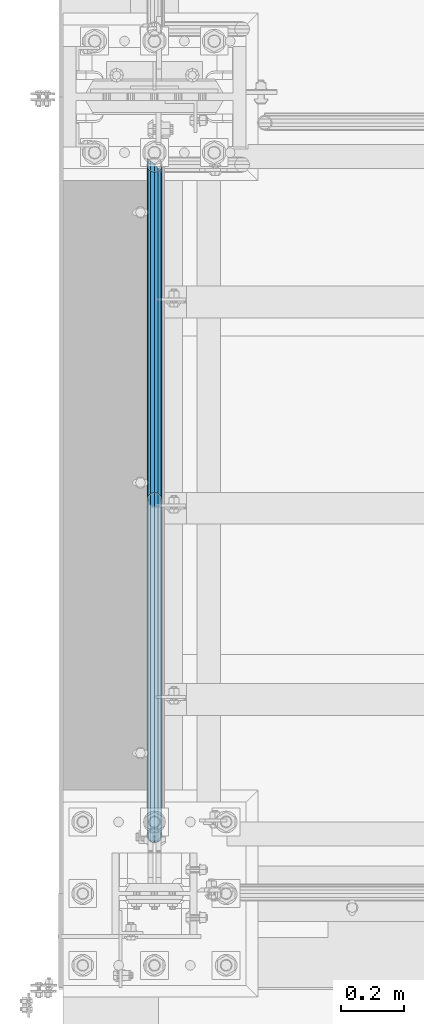
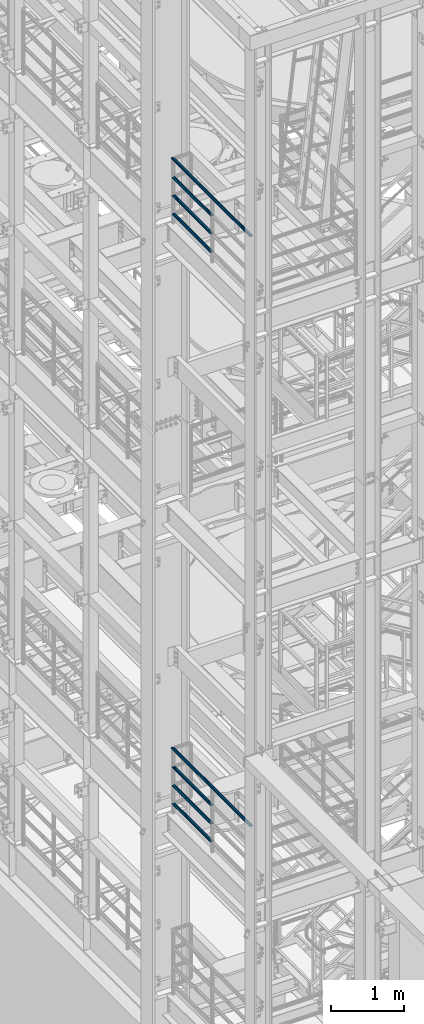
# One storey, part 952 of 1876: 8 beams, 2 elements without a shape of their own.
"""IFC2X3 building model written with IfcOpenShell, lengths in millimetres."""

from ifc_helpers import new_model, si_unit, frame, origin_with_axes, place, context, subcontext, project, spatial, faceted_brep, material, type_object, element, aggregate, save


model = new_model("IFC2X3")

# Units and contexts
model_context = context("Model", 3, precision=1e-05, world=origin_with_axes())
body_context = subcontext(model_context, "Body", "Model", "MODEL_VIEW")
ifc_project = project(units=[si_unit("LENGTHUNIT", "METRE", prefix="MILLI"), si_unit("AREAUNIT", "SQUARE_METRE"), si_unit("VOLUMEUNIT", "CUBIC_METRE"), si_unit("MASSUNIT", "GRAM", prefix="KILO"), si_unit("TIMEUNIT", "SECOND"), si_unit("PLANEANGLEUNIT", "RADIAN"), si_unit("SOLIDANGLEUNIT", "STERADIAN"), si_unit("THERMODYNAMICTEMPERATUREUNIT", "DEGREE_CELSIUS"), si_unit("LUMINOUSINTENSITYUNIT", "LUMEN")], contexts=[model_context])

# Site, building, storey
site_placement = place(None, origin_with_axes())
site = spatial("IfcSite", under=ifc_project, at=site_placement, CompositionType="ELEMENT")
building_placement = place(site_placement, origin_with_axes())
building = spatial("IfcBuilding", under=site, at=building_placement, Name="Undefined", CompositionType="ELEMENT")
storey_placement = place(building_placement, origin_with_axes())
storey = spatial("IfcBuildingStorey", under=building, at=storey_placement, Name="Undefined", CompositionType="ELEMENT", Elevation=0.0)

# Assembly, beams
assembly_1_placement = place(storey_placement, origin_with_axes())
assembly_1 = element("IfcElementAssembly", 1, at=assembly_1_placement, inside=storey, Name="RAIL", AssemblyPlace="NOTDEFINED", PredefinedType="RIGID_FRAME")
ifc_material = material()
beam_type = type_object("IfcBeamType", Name="PIPE1-1/2SCH40", PredefinedType="NOTDEFINED")
beam_1_placement = place(assembly_1_placement, frame((-2.52119318090435e-11, -4788.2175, 18145.125), z_axis=(0.0, 0.0, 1.0), x_axis=(0.0, -1.0, 0.0)))
beam_1 = element("IfcBeam", 2, at=beam_1_placement, type_object=beam_type, material=ifc_material, Name="RAIL", ObjectType="PIPE1-1/2SCH40", context=body_context, shape_type="Brep", body=[
    faceted_brep([(1047.96655700668, -12.0649999999996, 20.8971929933177), (1047.96655700668, -12.0649999999787, 15.8661214312015), (1047.47312856882, -10.2235000000001, 17.7076214311819), (1044.73375, 9.09494701772928e-13, 20.4470000000001), (1044.73375, 9.09494701772928e-13, 24.130000000001), (1047.47312856881, 10.2235000000001, 17.7076214311819), (1047.96655700668, 12.0650000000205, 15.8661214311578), (1047.96655700668, 12.0649999999996, 20.8971929933177), (1068.86375, 24.1300000000001, 0.0), (1056.79875, 20.8971929933186, 12.0649999999987), (1056.79875, 20.8971929933186, -12.0649999999987), (1053.60917843784, 17.7076214311801, 10.2235000000001), (1056.34855700666, 20.4470000000001, 0.0), (1053.60917843784, 17.7076214311801, -10.2235000000001), (1047.96655700668, 12.0650000000205, -15.8661214311578), (1047.96655700668, 12.0649999999996, -20.8971929933177), (1047.47312856881, 10.2235000000001, -17.7076214311819), (1044.73375, 0.0, -20.4470000000001), (1044.73375, 0.0, -24.130000000001), (1047.96655700668, -12.0649999999787, -15.8661214312015), (1047.96655700668, -12.0649999999996, -20.8971929933177), (1047.47312856882, -10.2235000000001, -17.7076214311819), (1068.86375, -24.1299999999792, 0.0), (1056.79875, -20.8971929933186, -12.0649999999987), (1056.79875, -20.8971929933186, 12.0649999999987), (1053.60917843788, -17.7076214311801, -10.2235000000001), (1056.3485570067, -20.4470000000001, 0.0), (1053.60917843788, -17.7076214311801, 10.2235000000001), (12.0650000000064, -20.8971929933177, -12.0649999999987), (20.8971929933249, -12.0650000000005, -20.8971929933177), (0.0, 24.1299999999992, 0.0), (12.0650000000064, 20.8971929933177, -12.0649999999987), (12.0650000000064, 20.8971929933177, 12.0649999999987), (20.8971929933249, 12.0650000000005, 20.8971929933177), (24.1300000000064, 0.0, 24.130000000001), (20.8971929933249, 12.0650000000005, -20.8971929933177), (24.1300000000063, 0.0, -24.130000000001), (24.1300000000063, 0.0, -20.4470000000001), (20.8971929933249, -12.0650000000005, -15.8661214311796), (21.3906214311868, -10.2235000000001, -17.7076214311819), (21.3906214311868, 10.2235000000001, -17.7076214311819), (20.8971929933249, 12.0650000000005, -15.8661214311796), (15.2545715621445, 17.7076214311801, -10.2235000000001), (12.5151929933249, 20.4470000000001, 0.0), (15.2545715621445, 17.7076214311801, 10.2235000000001), (20.8971929933249, 12.0650000000005, 15.8661214311796), (21.3906214311868, 10.2235000000001, 17.7076214311819), (24.1300000000064, 0.0, 20.4470000000001), (21.3906214311868, -10.2235000000001, 17.7076214311819), (20.8971929933249, -12.0650000000005, 15.8661214311796), (20.8971929933249, -12.0650000000005, 20.8971929933177), (12.0650000000064, -20.8971929933177, 12.0649999999987), (0.0, -24.1299999999992, 0.0), (15.2545715621445, -17.7076214311801, 10.2235000000001), (12.5151929933249, -20.4470000000001, 0.0), (15.2545715621445, -17.7076214311801, -10.2235000000001)], [[[0, 1, 2, 3, 4]], [[4, 3, 5, 6, 7]], [[8, 9, 10]], [[7, 6, 11, 12, 13, 14, 15, 10, 9]], [[16, 17, 18, 15, 14]], [[19, 20, 18, 17, 21]], [[22, 23, 24]], [[24, 23, 20, 19, 25, 26, 27, 1, 0]], [[28, 29, 20, 23]], [[30, 31, 32]], [[33, 34, 4, 7]], [[32, 33, 7, 9]], [[30, 32, 9, 8]], [[31, 30, 8, 10]], [[35, 31, 10, 15]], [[36, 35, 15, 18]], [[29, 36, 18, 20]], [[37, 36, 29, 38, 39]], [[40, 41, 35, 36, 37]], [[32, 31, 35, 41, 42, 43, 44, 45, 33]], [[33, 45, 46, 47, 34]], [[34, 47, 48, 49, 50]], [[34, 50, 0, 4]], [[50, 51, 24, 0]], [[51, 52, 22, 24]], [[52, 28, 23, 22]], [[51, 28, 52]], [[50, 49, 53, 54, 55, 38, 29, 28, 51]], [[55, 54, 26, 25]], [[21, 39, 38, 55, 25, 19]], [[37, 39, 21, 17]], [[40, 37, 17, 16]], [[42, 41, 40, 16, 14, 13]], [[43, 42, 13, 12]], [[44, 43, 12, 11]], [[5, 46, 45, 44, 11, 6]], [[47, 46, 5, 3]], [[48, 47, 3, 2]], [[53, 49, 48, 2, 1, 27]], [[54, 53, 27, 26]]]),
])
beam_2_placement = place(assembly_1_placement, frame((6.3664629124105e-12, -5857.08125, 18449.925), z_axis=(0.0, 0.0, -1.0), x_axis=(0.0, 1.0, 0.0)))
beam_2 = element("IfcBeam", 3, at=beam_2_placement, type_object=beam_type, material=ifc_material, Name="RAIL", ObjectType="PIPE1-1/2SCH40", context=body_context, shape_type="Brep", body=[
    faceted_brep([(0.0, 24.1299999999992, 0.0), (12.0650000000064, 20.8971929933177, -12.0649999999987), (12.0650000000064, 20.8971929933177, 12.0649999999987), (12.0650000000064, -20.8971929933177, 12.0649999999987), (12.0650000000064, -20.8971929933177, -12.0649999999987), (0.0, -24.1299999999992, 0.0), (20.8971929933249, -12.0650000000005, 20.8971929933177), (20.8971929933249, -12.0650000000005, 15.8661214311796), (15.2545715621445, -17.7076214311801, 10.2235000000001), (12.5151929933249, -20.4470000000001, 0.0), (15.2545715621445, -17.7076214311801, -10.2235000000001), (20.8971929933249, -12.0650000000005, -15.8661214311796), (20.8971929933249, -12.0650000000005, -20.8971929933177), (24.1300000000063, 0.0, -20.4470000000001), (24.1300000000063, 0.0, -24.130000000001), (21.3906214311868, -10.2235000000001, -17.7076214311819), (21.3906214311868, 10.2235000000001, -17.7076214311819), (20.8971929933249, 12.0650000000005, -15.8661214311796), (20.8971929933249, 12.0650000000005, -20.8971929933177), (15.2545715621445, 17.7076214311801, -10.2235000000001), (12.5151929933249, 20.4470000000001, 0.0), (15.2545715621445, 17.7076214311801, 10.2235000000001), (20.8971929933249, 12.0650000000005, 15.8661214311796), (20.8971929933249, 12.0650000000005, 20.8971929933177), (21.3906214311868, 10.2235000000001, 17.7076214311819), (24.1300000000064, 0.0, 20.4470000000001), (24.1300000000064, 0.0, 24.130000000001), (21.3906214311868, -10.2235000000001, 17.7076214311819), (1068.86375, 24.1300000000001, 0.0), (1056.79875, 20.8971929933186, -12.0649999999987), (1047.96655700668, 12.0649999999996, -20.8971929933177), (1068.86375, -24.1299999999792, 0.0), (1056.79875, -20.8971929933186, -12.0649999999987), (1056.79875, -20.8971929933186, 12.0649999999987), (1047.96655700668, -12.0649999999996, 20.8971929933177), (1047.96655700668, -12.0649999999996, -20.8971929933177), (1044.73375, 0.0, -24.130000000001), (1047.47312856881, 10.2235000000001, -17.7076214311819), (1044.73375, 0.0, -20.4470000000001), (1047.96655700668, 12.0650000000205, -15.8661214311578), (1047.96655700668, -12.0649999999787, -15.8661214312015), (1047.47312856882, -10.2235000000001, -17.7076214311819), (1053.60917843788, -17.7076214311801, -10.2235000000001), (1056.3485570067, -20.4470000000001, 0.0), (1053.60917843788, -17.7076214311801, 10.2235000000001), (1047.96655700668, -12.0649999999787, 15.8661214312015), (1047.47312856882, -10.2235000000001, 17.7076214311819), (1044.73375, 9.09494701772928e-13, 20.4470000000001), (1044.73375, 9.09494701772928e-13, 24.130000000001), (1047.96655700668, 12.0649999999996, 20.8971929933177), (1056.79875, 20.8971929933186, 12.0649999999987), (1047.96655700668, 12.0650000000205, 15.8661214311578), (1053.60917843784, 17.7076214311801, 10.2235000000001), (1056.34855700666, 20.4470000000001, 0.0), (1053.60917843784, 17.7076214311801, -10.2235000000001), (1047.47312856881, 10.2235000000001, 17.7076214311819)], [[[0, 1, 2]], [[3, 4, 5]], [[6, 7, 8, 9, 10, 11, 12, 4, 3]], [[13, 14, 12, 11, 15]], [[16, 17, 18, 14, 13]], [[2, 1, 18, 17, 19, 20, 21, 22, 23]], [[23, 22, 24, 25, 26]], [[26, 25, 27, 7, 6]], [[1, 0, 28, 29]], [[18, 1, 29, 30]], [[31, 32, 33]], [[6, 3, 33, 34]], [[3, 5, 31, 33]], [[5, 4, 32, 31]], [[4, 12, 35, 32]], [[12, 14, 36, 35]], [[14, 18, 30, 36]], [[37, 38, 36, 30, 39]], [[40, 35, 36, 38, 41]], [[33, 32, 35, 40, 42, 43, 44, 45, 34]], [[34, 45, 46, 47, 48]], [[26, 6, 34, 48]], [[2, 23, 49, 50]], [[23, 26, 48, 49]], [[0, 2, 50, 28]], [[28, 50, 29]], [[49, 51, 52, 53, 54, 39, 30, 29, 50]], [[48, 47, 55, 51, 49]], [[25, 24, 55, 47]], [[55, 24, 22, 21, 52, 51]], [[21, 20, 53, 52]], [[20, 19, 54, 53]], [[19, 17, 16, 37, 39, 54]], [[16, 13, 38, 37]], [[13, 15, 41, 38]], [[41, 15, 11, 10, 42, 40]], [[10, 9, 43, 42]], [[9, 8, 44, 43]], [[8, 7, 27, 46, 45, 44]], [[27, 25, 47, 46]]]),
])
beam_3_placement = place(assembly_1_placement, frame((6.3664629124105e-12, -5857.08125, 18754.725), z_axis=(0.0, 0.0, -1.0), x_axis=(0.0, 1.0, 0.0)))
beam_3 = element("IfcBeam", 4, at=beam_3_placement, type_object=beam_type, material=ifc_material, Name="RAIL", ObjectType="PIPE1-1/2SCH40", context=body_context, shape_type="Brep", body=[
    faceted_brep([(0.0, 24.1299999999992, 0.0), (12.0650000000064, 20.8971929933177, -12.0649999999987), (12.0650000000064, 20.8971929933177, 12.0649999999987), (12.0650000000064, -20.8971929933177, 12.0649999999987), (12.0650000000064, -20.8971929933177, -12.0649999999987), (0.0, -24.1299999999992, 0.0), (20.8971929933249, -12.0650000000005, 20.8971929933177), (20.8971929933249, -12.0650000000005, 15.8661214311796), (15.2545715621445, -17.7076214311801, 10.2235000000001), (12.5151929933249, -20.4470000000001, 0.0), (15.2545715621445, -17.7076214311801, -10.2235000000001), (20.8971929933249, -12.0650000000005, -15.8661214311796), (20.8971929933249, -12.0650000000005, -20.8971929933177), (24.1300000000063, 0.0, -20.4470000000001), (24.1300000000063, 0.0, -24.130000000001), (21.3906214311868, -10.2235000000001, -17.7076214311819), (21.3906214311868, 10.2235000000001, -17.7076214311819), (20.8971929933249, 12.0650000000005, -15.8661214311796), (20.8971929933249, 12.0650000000005, -20.8971929933177), (15.2545715621445, 17.7076214311801, -10.2235000000001), (12.5151929933249, 20.4470000000001, 0.0), (15.2545715621445, 17.7076214311801, 10.2235000000001), (20.8971929933249, 12.0650000000005, 15.8661214311796), (20.8971929933249, 12.0650000000005, 20.8971929933177), (21.3906214311868, 10.2235000000001, 17.7076214311819), (24.1300000000064, 0.0, 20.4470000000001), (24.1300000000064, 0.0, 24.130000000001), (21.3906214311868, -10.2235000000001, 17.7076214311819), (1068.86375, 24.1300000000001, 0.0), (1056.79875, 20.8971929933186, -12.0649999999987), (1047.96655700668, 12.0649999999996, -20.8971929933177), (1068.86375, -24.1299999999792, 0.0), (1056.79875, -20.8971929933186, -12.0649999999987), (1056.79875, -20.8971929933186, 12.0649999999987), (1047.96655700668, -12.0649999999996, 20.8971929933177), (1047.96655700668, -12.0649999999996, -20.8971929933177), (1044.73375, 0.0, -24.130000000001), (1047.47312856881, 10.2235000000001, -17.7076214311819), (1044.73375, 0.0, -20.4470000000001), (1047.96655700668, 12.0650000000205, -15.8661214311578), (1047.96655700668, -12.0649999999787, -15.8661214312015), (1047.47312856882, -10.2235000000001, -17.7076214311819), (1053.60917843788, -17.7076214311801, -10.2235000000001), (1056.3485570067, -20.4470000000001, 0.0), (1053.60917843788, -17.7076214311801, 10.2235000000001), (1047.96655700668, -12.0649999999787, 15.8661214312015), (1047.47312856882, -10.2235000000001, 17.7076214311819), (1044.73375, 9.09494701772928e-13, 20.4470000000001), (1044.73375, 9.09494701772928e-13, 24.130000000001), (1047.96655700668, 12.0649999999996, 20.8971929933177), (1056.79875, 20.8971929933186, 12.0649999999987), (1047.96655700668, 12.0650000000205, 15.8661214311578), (1053.60917843784, 17.7076214311801, 10.2235000000001), (1056.34855700666, 20.4470000000001, 0.0), (1053.60917843784, 17.7076214311801, -10.2235000000001), (1047.47312856881, 10.2235000000001, 17.7076214311819)], [[[0, 1, 2]], [[3, 4, 5]], [[6, 7, 8, 9, 10, 11, 12, 4, 3]], [[13, 14, 12, 11, 15]], [[16, 17, 18, 14, 13]], [[2, 1, 18, 17, 19, 20, 21, 22, 23]], [[23, 22, 24, 25, 26]], [[26, 25, 27, 7, 6]], [[1, 0, 28, 29]], [[18, 1, 29, 30]], [[31, 32, 33]], [[6, 3, 33, 34]], [[3, 5, 31, 33]], [[5, 4, 32, 31]], [[4, 12, 35, 32]], [[12, 14, 36, 35]], [[14, 18, 30, 36]], [[37, 38, 36, 30, 39]], [[40, 35, 36, 38, 41]], [[33, 32, 35, 40, 42, 43, 44, 45, 34]], [[34, 45, 46, 47, 48]], [[26, 6, 34, 48]], [[2, 23, 49, 50]], [[23, 26, 48, 49]], [[0, 2, 50, 28]], [[28, 50, 29]], [[49, 51, 52, 53, 54, 39, 30, 29, 50]], [[48, 47, 55, 51, 49]], [[25, 24, 55, 47]], [[55, 24, 22, 21, 52, 51]], [[21, 20, 53, 52]], [[20, 19, 54, 53]], [[19, 17, 16, 37, 39, 54]], [[16, 13, 38, 37]], [[13, 15, 41, 38]], [[41, 15, 11, 10, 42, 40]], [[10, 9, 43, 42]], [[9, 8, 44, 43]], [[8, 7, 27, 46, 45, 44]], [[27, 25, 47, 46]]]),
])
beam_4_placement = place(assembly_1_placement, frame((1.45519152283669e-11, -6950.075, 19059.525), z_axis=(0.0, 0.0, -1.0), x_axis=(0.0, 1.0, 0.0)))
beam_4 = element("IfcBeam", 5, at=beam_4_placement, type_object=beam_type, material=ifc_material, Name="RAIL", ObjectType="PIPE1-1/2SCH40", context=body_context, shape_type="Brep", body=[
    faceted_brep([(24.1300000000001, -20.4469999999999, 0.0), (34.3535000000002, -17.7076214311803, 10.2235000000001), (2179.56512143117, -17.7076214311804, 10.2235000000001), (2182.30449999999, -20.447, 0.0), (41.8376214311802, -10.2235000000001, 17.7076214311819), (2172.08099999999, -10.2235, 17.7076214311819), (44.5770000000002, 0.0, 20.4470000000001), (2161.8575, 0.0, 20.4470000000001), (41.8376214311802, 10.2235000000001, 17.7076214311819), (2151.63399999999, 10.2235, 17.7076214311819), (34.3535000000002, 17.7076214311803, 10.2235000000001), (2144.14987856881, 17.7076214311804, 10.2235000000001), (24.1300000000001, 20.4469999999999, 0.0), (2141.41049999999, 20.447, 0.0), (13.9065000000001, 17.7076214311803, -10.2235000000001), (2144.14987856881, 17.7076214311804, -10.2235000000001), (6.42237856882002, 10.2235000000001, -17.7076214311819), (2151.63399999999, 10.2235, -17.7076214311819), (3.68299999999999, 0.0, -20.4470000000001), (2161.8575, 0.0, -20.4470000000001), (6.42237856882002, -10.2235000000001, -17.7076214311819), (2172.08099999999, -10.2235, -17.7076214311819), (13.9065000000001, -17.7076214311803, -10.2235000000001), (2179.56512143117, -17.7076214311804, -10.2235000000001), (24.1299999999854, -24.1299999999992, 0.0), (12.0650000000064, -20.8971929933177, -12.0649999999987), (2182.75469299331, -20.8971929933185, -12.0649999999987), (2185.98749999999, -24.13, 0.0), (3.23280700668147, -12.0650000000001, -20.8971929933177), (2173.9225, -12.065, -20.8971929933177), (-1.45519152283669e-11, 0.0, -24.130000000001), (2161.8575, 0.0, -24.130000000001), (3.23280700668147, 12.0650000000001, -20.8971929933177), (2149.79249999999, 12.065, -20.8971929933177), (12.0650000000064, 20.8971929933177, -12.0649999999987), (2140.96030700668, 20.8971929933185, -12.0649999999987), (24.1300000000047, 24.1299999999992, 0.0), (2137.72749999999, 24.13, 0.0), (36.1949999999997, 20.8971929933184, 12.0649999999987), (2140.96030700668, 20.8971929933185, 12.0649999999987), (45.0271929933187, 12.0650000000001, 20.8971929933177), (2149.79249999999, 12.065, 20.8971929933177), (48.2600000000002, 0.0, 24.130000000001), (2161.8575, 0.0, 24.130000000001), (45.0271929933187, -12.0650000000001, 20.8971929933177), (2173.9225, -12.065, 20.8971929933177), (36.1949999999997, -20.8971929933184, 12.0649999999987), (2182.75469299331, -20.8971929933185, 12.0649999999987)], [[[0, 1, 2, 3]], [[1, 4, 5, 2]], [[4, 6, 7, 5]], [[6, 8, 9, 7]], [[8, 10, 11, 9]], [[10, 12, 13, 11]], [[12, 14, 15, 13]], [[14, 16, 17, 15]], [[16, 18, 19, 17]], [[18, 20, 21, 19]], [[20, 22, 23, 21]], [[22, 0, 3, 23]], [[24, 25, 26, 27]], [[25, 28, 29, 26]], [[28, 30, 31, 29]], [[30, 32, 33, 31]], [[32, 34, 35, 33]], [[34, 36, 37, 35]], [[36, 38, 39, 37]], [[38, 40, 41, 39]], [[40, 42, 43, 41]], [[42, 44, 45, 43]], [[44, 46, 47, 45]], [[46, 24, 27, 47]], [[29, 31, 33, 35, 37, 39, 41, 43, 45, 47, 27, 26], [5, 7, 9, 11, 13, 15, 17, 19, 21, 23, 3, 2]], [[46, 44, 42, 40, 38, 36, 34, 32, 30, 28, 25, 24], [22, 20, 18, 16, 14, 12, 10, 8, 6, 4, 1, 0]]]),
])
aggregate(assembly_1, [beam_1, beam_2, beam_3, beam_4])

assembly_2_placement = place(storey_placement, origin_with_axes())
assembly_2 = element("IfcElementAssembly", 6, at=assembly_2_placement, inside=storey, Name="RAIL", AssemblyPlace="NOTDEFINED", PredefinedType="RIGID_FRAME")
beam_5_placement = place(assembly_2_placement, frame((-2.52119318090435e-11, -4788.2175, 8315.325), z_axis=(0.0, 0.0, 1.0), x_axis=(0.0, -1.0, 0.0)))
beam_5 = element("IfcBeam", 7, at=beam_5_placement, type_object=beam_type, material=ifc_material, Name="RAIL", ObjectType="PIPE1-1/2SCH40", context=body_context, shape_type="Brep", body=[
    faceted_brep([(1047.96655700668, -12.0649999999996, 20.8971929933177), (1047.96655700668, -12.0649999999787, 15.8661214312015), (1047.47312856882, -10.2235000000001, 17.7076214311819), (1044.73375, 9.09494701772928e-13, 20.4470000000001), (1044.73375, 9.09494701772928e-13, 24.130000000001), (1047.47312856881, 10.2235000000001, 17.7076214311819), (1047.96655700668, 12.0650000000205, 15.8661214311578), (1047.96655700668, 12.0649999999996, 20.8971929933177), (1068.86375, 24.1300000000001, 0.0), (1056.79875, 20.8971929933186, 12.0649999999987), (1056.79875, 20.8971929933186, -12.0649999999987), (1053.60917843784, 17.7076214311801, 10.2235000000001), (1056.34855700666, 20.4470000000001, 0.0), (1053.60917843784, 17.7076214311801, -10.2235000000001), (1047.96655700668, 12.0650000000205, -15.8661214311578), (1047.96655700668, 12.0649999999996, -20.8971929933177), (1047.47312856881, 10.2235000000001, -17.7076214311819), (1044.73375, 0.0, -20.4470000000001), (1044.73375, 0.0, -24.130000000001), (1047.96655700668, -12.0649999999787, -15.8661214312015), (1047.96655700668, -12.0649999999996, -20.8971929933177), (1047.47312856882, -10.2235000000001, -17.7076214311819), (1068.86375, -24.1299999999792, 0.0), (1056.79875, -20.8971929933186, -12.0649999999987), (1056.79875, -20.8971929933186, 12.0649999999987), (1053.60917843788, -17.7076214311801, -10.2235000000001), (1056.3485570067, -20.4470000000001, 0.0), (1053.60917843788, -17.7076214311801, 10.2235000000001), (12.0650000000064, -20.8971929933177, -12.0649999999987), (20.8971929933249, -12.0650000000005, -20.8971929933177), (0.0, 24.1299999999992, 0.0), (12.0650000000064, 20.8971929933177, -12.0649999999987), (12.0650000000064, 20.8971929933177, 12.0649999999987), (20.8971929933249, 12.0650000000005, 20.8971929933177), (24.1300000000064, 0.0, 24.130000000001), (20.8971929933249, 12.0650000000005, -20.8971929933177), (24.1300000000063, 0.0, -24.130000000001), (24.1300000000063, 0.0, -20.4470000000001), (20.8971929933249, -12.0650000000005, -15.8661214311796), (21.3906214311868, -10.2235000000001, -17.7076214311819), (21.3906214311868, 10.2235000000001, -17.7076214311819), (20.8971929933249, 12.0650000000005, -15.8661214311796), (15.2545715621445, 17.7076214311801, -10.2235000000001), (12.5151929933249, 20.4470000000001, 0.0), (15.2545715621445, 17.7076214311801, 10.2235000000001), (20.8971929933249, 12.0650000000005, 15.8661214311796), (21.3906214311868, 10.2235000000001, 17.7076214311819), (24.1300000000064, 0.0, 20.4470000000001), (21.3906214311868, -10.2235000000001, 17.7076214311819), (20.8971929933249, -12.0650000000005, 15.8661214311796), (20.8971929933249, -12.0650000000005, 20.8971929933177), (12.0650000000064, -20.8971929933177, 12.0649999999987), (0.0, -24.1299999999992, 0.0), (15.2545715621445, -17.7076214311801, 10.2235000000001), (12.5151929933249, -20.4470000000001, 0.0), (15.2545715621445, -17.7076214311801, -10.2235000000001)], [[[0, 1, 2, 3, 4]], [[4, 3, 5, 6, 7]], [[8, 9, 10]], [[7, 6, 11, 12, 13, 14, 15, 10, 9]], [[16, 17, 18, 15, 14]], [[19, 20, 18, 17, 21]], [[22, 23, 24]], [[24, 23, 20, 19, 25, 26, 27, 1, 0]], [[28, 29, 20, 23]], [[30, 31, 32]], [[33, 34, 4, 7]], [[32, 33, 7, 9]], [[30, 32, 9, 8]], [[31, 30, 8, 10]], [[35, 31, 10, 15]], [[36, 35, 15, 18]], [[29, 36, 18, 20]], [[37, 36, 29, 38, 39]], [[40, 41, 35, 36, 37]], [[32, 31, 35, 41, 42, 43, 44, 45, 33]], [[33, 45, 46, 47, 34]], [[34, 47, 48, 49, 50]], [[34, 50, 0, 4]], [[50, 51, 24, 0]], [[51, 52, 22, 24]], [[52, 28, 23, 22]], [[51, 28, 52]], [[50, 49, 53, 54, 55, 38, 29, 28, 51]], [[55, 54, 26, 25]], [[21, 39, 38, 55, 25, 19]], [[37, 39, 21, 17]], [[40, 37, 17, 16]], [[42, 41, 40, 16, 14, 13]], [[43, 42, 13, 12]], [[44, 43, 12, 11]], [[5, 46, 45, 44, 11, 6]], [[47, 46, 5, 3]], [[48, 47, 3, 2]], [[53, 49, 48, 2, 1, 27]], [[54, 53, 27, 26]]]),
])
beam_6_placement = place(assembly_2_placement, frame((6.3664629124105e-12, -5857.08125, 8620.125), z_axis=(0.0, 0.0, -1.0), x_axis=(0.0, 1.0, 0.0)))
beam_6 = element("IfcBeam", 8, at=beam_6_placement, type_object=beam_type, material=ifc_material, Name="RAIL", ObjectType="PIPE1-1/2SCH40", context=body_context, shape_type="Brep", body=[
    faceted_brep([(0.0, 24.1299999999992, 0.0), (12.0650000000064, 20.8971929933177, -12.0649999999987), (12.0650000000064, 20.8971929933177, 12.0649999999987), (12.0650000000064, -20.8971929933177, 12.0649999999987), (12.0650000000064, -20.8971929933177, -12.0649999999987), (0.0, -24.1299999999992, 0.0), (20.8971929933249, -12.0650000000005, 20.8971929933177), (20.8971929933249, -12.0650000000005, 15.8661214311796), (15.2545715621445, -17.7076214311801, 10.2235000000001), (12.5151929933249, -20.4470000000001, 0.0), (15.2545715621445, -17.7076214311801, -10.2235000000001), (20.8971929933249, -12.0650000000005, -15.8661214311796), (20.8971929933249, -12.0650000000005, -20.8971929933177), (24.1300000000063, 0.0, -20.4470000000001), (24.1300000000063, 0.0, -24.130000000001), (21.3906214311868, -10.2235000000001, -17.7076214311819), (21.3906214311868, 10.2235000000001, -17.7076214311819), (20.8971929933249, 12.0650000000005, -15.8661214311796), (20.8971929933249, 12.0650000000005, -20.8971929933177), (15.2545715621445, 17.7076214311801, -10.2235000000001), (12.5151929933249, 20.4470000000001, 0.0), (15.2545715621445, 17.7076214311801, 10.2235000000001), (20.8971929933249, 12.0650000000005, 15.8661214311796), (20.8971929933249, 12.0650000000005, 20.8971929933177), (21.3906214311868, 10.2235000000001, 17.7076214311819), (24.1300000000064, 0.0, 20.4470000000001), (24.1300000000064, 0.0, 24.130000000001), (21.3906214311868, -10.2235000000001, 17.7076214311819), (1068.86375, 24.1300000000001, 0.0), (1056.79875, 20.8971929933186, -12.0649999999987), (1047.96655700668, 12.0649999999996, -20.8971929933177), (1068.86375, -24.1299999999792, 0.0), (1056.79875, -20.8971929933186, -12.0649999999987), (1056.79875, -20.8971929933186, 12.0649999999987), (1047.96655700668, -12.0649999999996, 20.8971929933177), (1047.96655700668, -12.0649999999996, -20.8971929933177), (1044.73375, 0.0, -24.130000000001), (1047.47312856881, 10.2235000000001, -17.7076214311819), (1044.73375, 0.0, -20.4470000000001), (1047.96655700668, 12.0650000000205, -15.8661214311578), (1047.96655700668, -12.0649999999787, -15.8661214312015), (1047.47312856882, -10.2235000000001, -17.7076214311819), (1053.60917843788, -17.7076214311801, -10.2235000000001), (1056.3485570067, -20.4470000000001, 0.0), (1053.60917843788, -17.7076214311801, 10.2235000000001), (1047.96655700668, -12.0649999999787, 15.8661214312015), (1047.47312856882, -10.2235000000001, 17.7076214311819), (1044.73375, 9.09494701772928e-13, 20.4470000000001), (1044.73375, 9.09494701772928e-13, 24.130000000001), (1047.96655700668, 12.0649999999996, 20.8971929933177), (1056.79875, 20.8971929933186, 12.0649999999987), (1047.96655700668, 12.0650000000205, 15.8661214311578), (1053.60917843784, 17.7076214311801, 10.2235000000001), (1056.34855700666, 20.4470000000001, 0.0), (1053.60917843784, 17.7076214311801, -10.2235000000001), (1047.47312856881, 10.2235000000001, 17.7076214311819)], [[[0, 1, 2]], [[3, 4, 5]], [[6, 7, 8, 9, 10, 11, 12, 4, 3]], [[13, 14, 12, 11, 15]], [[16, 17, 18, 14, 13]], [[2, 1, 18, 17, 19, 20, 21, 22, 23]], [[23, 22, 24, 25, 26]], [[26, 25, 27, 7, 6]], [[1, 0, 28, 29]], [[18, 1, 29, 30]], [[31, 32, 33]], [[6, 3, 33, 34]], [[3, 5, 31, 33]], [[5, 4, 32, 31]], [[4, 12, 35, 32]], [[12, 14, 36, 35]], [[14, 18, 30, 36]], [[37, 38, 36, 30, 39]], [[40, 35, 36, 38, 41]], [[33, 32, 35, 40, 42, 43, 44, 45, 34]], [[34, 45, 46, 47, 48]], [[26, 6, 34, 48]], [[2, 23, 49, 50]], [[23, 26, 48, 49]], [[0, 2, 50, 28]], [[28, 50, 29]], [[49, 51, 52, 53, 54, 39, 30, 29, 50]], [[48, 47, 55, 51, 49]], [[25, 24, 55, 47]], [[55, 24, 22, 21, 52, 51]], [[21, 20, 53, 52]], [[20, 19, 54, 53]], [[19, 17, 16, 37, 39, 54]], [[16, 13, 38, 37]], [[13, 15, 41, 38]], [[41, 15, 11, 10, 42, 40]], [[10, 9, 43, 42]], [[9, 8, 44, 43]], [[8, 7, 27, 46, 45, 44]], [[27, 25, 47, 46]]]),
])
beam_7_placement = place(assembly_2_placement, frame((6.3664629124105e-12, -5857.08125, 8924.925), z_axis=(0.0, 0.0, -1.0), x_axis=(0.0, 1.0, 0.0)))
beam_7 = element("IfcBeam", 9, at=beam_7_placement, type_object=beam_type, material=ifc_material, Name="RAIL", ObjectType="PIPE1-1/2SCH40", context=body_context, shape_type="Brep", body=[
    faceted_brep([(0.0, 24.1299999999992, 0.0), (12.0650000000064, 20.8971929933177, -12.0649999999987), (12.0650000000064, 20.8971929933177, 12.0649999999987), (12.0650000000064, -20.8971929933177, 12.0649999999987), (12.0650000000064, -20.8971929933177, -12.0649999999987), (0.0, -24.1299999999992, 0.0), (20.8971929933249, -12.0650000000005, 20.8971929933177), (20.8971929933249, -12.0650000000005, 15.8661214311796), (15.2545715621445, -17.7076214311801, 10.2235000000001), (12.5151929933249, -20.4470000000001, 0.0), (15.2545715621445, -17.7076214311801, -10.2235000000001), (20.8971929933249, -12.0650000000005, -15.8661214311796), (20.8971929933249, -12.0650000000005, -20.8971929933177), (24.1300000000063, 0.0, -20.4470000000001), (24.1300000000063, 0.0, -24.130000000001), (21.3906214311868, -10.2235000000001, -17.7076214311819), (21.3906214311868, 10.2235000000001, -17.7076214311819), (20.8971929933249, 12.0650000000005, -15.8661214311796), (20.8971929933249, 12.0650000000005, -20.8971929933177), (15.2545715621445, 17.7076214311801, -10.2235000000001), (12.5151929933249, 20.4470000000001, 0.0), (15.2545715621445, 17.7076214311801, 10.2235000000001), (20.8971929933249, 12.0650000000005, 15.8661214311796), (20.8971929933249, 12.0650000000005, 20.8971929933177), (21.3906214311868, 10.2235000000001, 17.7076214311819), (24.1300000000064, 0.0, 20.4470000000001), (24.1300000000064, 0.0, 24.130000000001), (21.3906214311868, -10.2235000000001, 17.7076214311819), (1068.86375, 24.1300000000001, 0.0), (1056.79875, 20.8971929933186, -12.0649999999987), (1047.96655700668, 12.0649999999996, -20.8971929933177), (1068.86375, -24.1299999999792, 0.0), (1056.79875, -20.8971929933186, -12.0649999999987), (1056.79875, -20.8971929933186, 12.0649999999987), (1047.96655700668, -12.0649999999996, 20.8971929933177), (1047.96655700668, -12.0649999999996, -20.8971929933177), (1044.73375, 0.0, -24.130000000001), (1047.47312856881, 10.2235000000001, -17.7076214311819), (1044.73375, 0.0, -20.4470000000001), (1047.96655700668, 12.0650000000205, -15.8661214311578), (1047.96655700668, -12.0649999999787, -15.8661214312015), (1047.47312856882, -10.2235000000001, -17.7076214311819), (1053.60917843788, -17.7076214311801, -10.2235000000001), (1056.3485570067, -20.4470000000001, 0.0), (1053.60917843788, -17.7076214311801, 10.2235000000001), (1047.96655700668, -12.0649999999787, 15.8661214312015), (1047.47312856882, -10.2235000000001, 17.7076214311819), (1044.73375, 9.09494701772928e-13, 20.4470000000001), (1044.73375, 9.09494701772928e-13, 24.130000000001), (1047.96655700668, 12.0649999999996, 20.8971929933177), (1056.79875, 20.8971929933186, 12.0649999999987), (1047.96655700668, 12.0650000000205, 15.8661214311578), (1053.60917843784, 17.7076214311801, 10.2235000000001), (1056.34855700666, 20.4470000000001, 0.0), (1053.60917843784, 17.7076214311801, -10.2235000000001), (1047.47312856881, 10.2235000000001, 17.7076214311819)], [[[0, 1, 2]], [[3, 4, 5]], [[6, 7, 8, 9, 10, 11, 12, 4, 3]], [[13, 14, 12, 11, 15]], [[16, 17, 18, 14, 13]], [[2, 1, 18, 17, 19, 20, 21, 22, 23]], [[23, 22, 24, 25, 26]], [[26, 25, 27, 7, 6]], [[1, 0, 28, 29]], [[18, 1, 29, 30]], [[31, 32, 33]], [[6, 3, 33, 34]], [[3, 5, 31, 33]], [[5, 4, 32, 31]], [[4, 12, 35, 32]], [[12, 14, 36, 35]], [[14, 18, 30, 36]], [[37, 38, 36, 30, 39]], [[40, 35, 36, 38, 41]], [[33, 32, 35, 40, 42, 43, 44, 45, 34]], [[34, 45, 46, 47, 48]], [[26, 6, 34, 48]], [[2, 23, 49, 50]], [[23, 26, 48, 49]], [[0, 2, 50, 28]], [[28, 50, 29]], [[49, 51, 52, 53, 54, 39, 30, 29, 50]], [[48, 47, 55, 51, 49]], [[25, 24, 55, 47]], [[55, 24, 22, 21, 52, 51]], [[21, 20, 53, 52]], [[20, 19, 54, 53]], [[19, 17, 16, 37, 39, 54]], [[16, 13, 38, 37]], [[13, 15, 41, 38]], [[41, 15, 11, 10, 42, 40]], [[10, 9, 43, 42]], [[9, 8, 44, 43]], [[8, 7, 27, 46, 45, 44]], [[27, 25, 47, 46]]]),
])
beam_8_placement = place(assembly_2_placement, frame((1.45519152283669e-11, -6950.075, 9229.725), z_axis=(0.0, 0.0, -1.0), x_axis=(0.0, 1.0, 0.0)))
beam_8 = element("IfcBeam", 10, at=beam_8_placement, type_object=beam_type, material=ifc_material, Name="RAIL", ObjectType="PIPE1-1/2SCH40", context=body_context, shape_type="Brep", body=[
    faceted_brep([(24.1300000000001, -20.4469999999999, 0.0), (34.3535000000002, -17.7076214311803, 10.2235000000001), (2179.56512143117, -17.7076214311804, 10.2235000000001), (2182.30449999999, -20.447, 0.0), (41.8376214311802, -10.2235000000001, 17.7076214311819), (2172.08099999999, -10.2235, 17.7076214311819), (44.5770000000002, 0.0, 20.4470000000001), (2161.8575, 0.0, 20.4470000000001), (41.8376214311802, 10.2235000000001, 17.7076214311819), (2151.63399999999, 10.2235, 17.7076214311819), (34.3535000000002, 17.7076214311803, 10.2235000000001), (2144.14987856881, 17.7076214311804, 10.2235000000001), (24.1300000000001, 20.4469999999999, 0.0), (2141.41049999999, 20.447, 0.0), (13.9065000000001, 17.7076214311803, -10.2235000000001), (2144.14987856881, 17.7076214311804, -10.2235000000001), (6.42237856882002, 10.2235000000001, -17.7076214311819), (2151.63399999999, 10.2235, -17.7076214311819), (3.68299999999999, 0.0, -20.4470000000001), (2161.8575, 0.0, -20.4470000000001), (6.42237856882002, -10.2235000000001, -17.7076214311819), (2172.08099999999, -10.2235, -17.7076214311819), (13.9065000000001, -17.7076214311803, -10.2235000000001), (2179.56512143117, -17.7076214311804, -10.2235000000001), (24.1299999999854, -24.1299999999992, 0.0), (12.0650000000064, -20.8971929933177, -12.0649999999987), (2182.75469299331, -20.8971929933185, -12.0649999999987), (2185.98749999999, -24.13, 0.0), (3.23280700668147, -12.0650000000001, -20.8971929933177), (2173.9225, -12.065, -20.8971929933177), (-1.45519152283669e-11, 0.0, -24.130000000001), (2161.8575, 0.0, -24.130000000001), (3.23280700668147, 12.0650000000001, -20.8971929933177), (2149.79249999999, 12.065, -20.8971929933177), (12.0650000000064, 20.8971929933177, -12.0649999999987), (2140.96030700668, 20.8971929933185, -12.0649999999987), (24.1300000000047, 24.1299999999992, 0.0), (2137.72749999999, 24.13, 0.0), (36.1949999999997, 20.8971929933184, 12.0649999999987), (2140.96030700668, 20.8971929933185, 12.0649999999987), (45.0271929933187, 12.0650000000001, 20.8971929933177), (2149.79249999999, 12.065, 20.8971929933177), (48.2600000000002, 0.0, 24.130000000001), (2161.8575, 0.0, 24.130000000001), (45.0271929933187, -12.0650000000001, 20.8971929933177), (2173.9225, -12.065, 20.8971929933177), (36.1949999999997, -20.8971929933184, 12.0649999999987), (2182.75469299331, -20.8971929933185, 12.0649999999987)], [[[0, 1, 2, 3]], [[1, 4, 5, 2]], [[4, 6, 7, 5]], [[6, 8, 9, 7]], [[8, 10, 11, 9]], [[10, 12, 13, 11]], [[12, 14, 15, 13]], [[14, 16, 17, 15]], [[16, 18, 19, 17]], [[18, 20, 21, 19]], [[20, 22, 23, 21]], [[22, 0, 3, 23]], [[24, 25, 26, 27]], [[25, 28, 29, 26]], [[28, 30, 31, 29]], [[30, 32, 33, 31]], [[32, 34, 35, 33]], [[34, 36, 37, 35]], [[36, 38, 39, 37]], [[38, 40, 41, 39]], [[40, 42, 43, 41]], [[42, 44, 45, 43]], [[44, 46, 47, 45]], [[46, 24, 27, 47]], [[29, 31, 33, 35, 37, 39, 41, 43, 45, 47, 27, 26], [5, 7, 9, 11, 13, 15, 17, 19, 21, 23, 3, 2]], [[46, 44, 42, 40, 38, 36, 34, 32, 30, 28, 25, 24], [22, 20, 18, 16, 14, 12, 10, 8, 6, 4, 1, 0]]]),
])
aggregate(assembly_2, [beam_5, beam_6, beam_7, beam_8])

save(model, "model.ifc")
